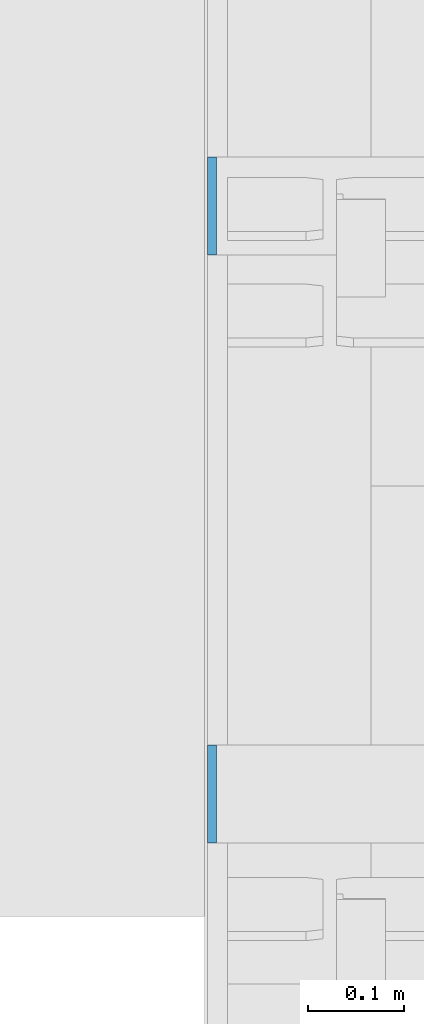
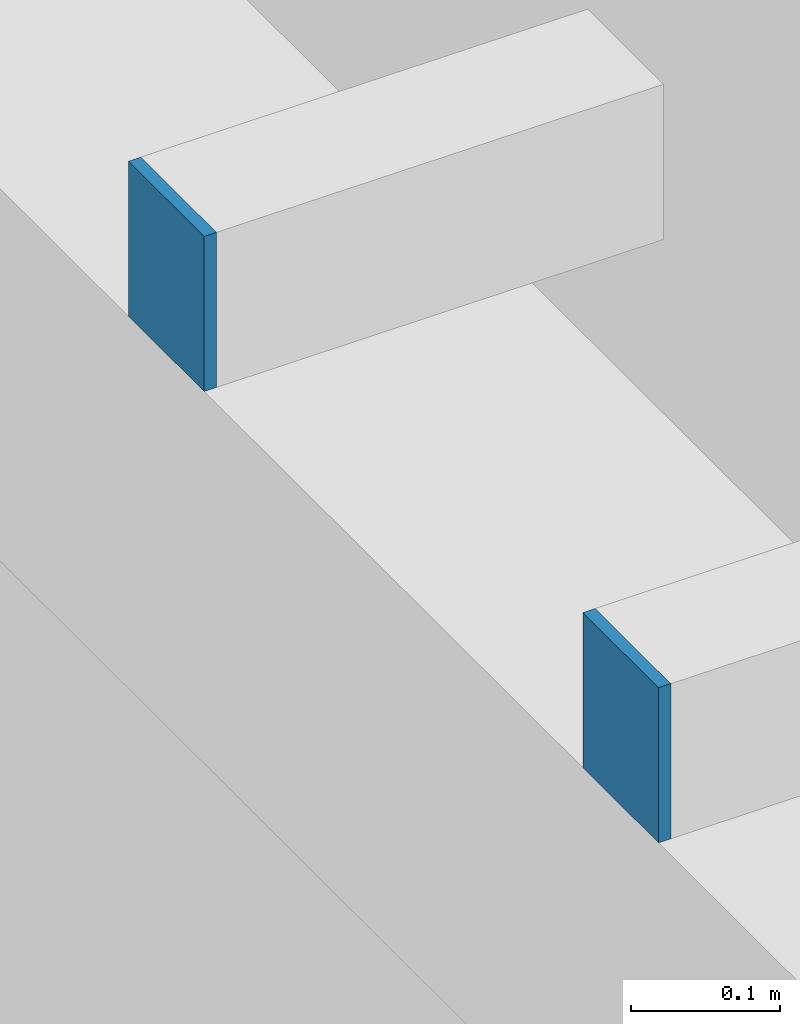
# One storey, part 461 of 1179: 2 columns, 2 elements without a shape of their own.
"""IFC2X3 building model written with IfcOpenShell, lengths in millimetres."""

from ifc_helpers import new_model, si_unit, frame, origin_with_axes, place, context, subcontext, project, spatial, faceted_brep, material, type_object, element, aggregate, save


model = new_model("IFC2X3")

# Units and contexts
model_context = context("Model", 3, precision=1e-05, world=origin_with_axes())
body_context = subcontext(model_context, "Body", "Model", "MODEL_VIEW")
ifc_project = project(units=[si_unit("LENGTHUNIT", "METRE", prefix="MILLI"), si_unit("AREAUNIT", "SQUARE_METRE"), si_unit("VOLUMEUNIT", "CUBIC_METRE"), si_unit("MASSUNIT", "GRAM", prefix="KILO"), si_unit("TIMEUNIT", "SECOND"), si_unit("PLANEANGLEUNIT", "RADIAN"), si_unit("SOLIDANGLEUNIT", "STERADIAN"), si_unit("THERMODYNAMICTEMPERATUREUNIT", "DEGREE_CELSIUS"), si_unit("LUMINOUSINTENSITYUNIT", "LUMEN")], contexts=[model_context])

# Site, building, storey
site_placement = place(None, origin_with_axes())
site = spatial("IfcSite", under=ifc_project, at=site_placement, CompositionType="ELEMENT")
building_placement = place(site_placement, origin_with_axes())
building = spatial("IfcBuilding", under=site, at=building_placement, Name="Undefined", CompositionType="ELEMENT")
storey_placement = place(building_placement, origin_with_axes())
storey = spatial("IfcBuildingStorey", under=building, at=storey_placement, Name="Undefined", CompositionType="ELEMENT", Elevation=0.0)

# Assembly, column
assembly_1_placement = place(storey_placement, origin_with_axes())
assembly_1 = element("IfcElementAssembly", 1, at=assembly_1_placement, inside=storey, Name="BEAM", AssemblyPlace="NOTDEFINED", PredefinedType="RIGID_FRAME")
ifc_material = material(Name="STEEL/A36")
column_type = type_object("IfcColumnType", PredefinedType="NOTDEFINED")
column_1_placement = place(assembly_1_placement, frame((24185.5625, 25577.8, 8013.69999998781), z_axis=(0.0, -1.0, 0.0), x_axis=(0.0, 0.0, 1.0)))
column_1 = element("IfcColumn", 2, at=column_1_placement, type_object=column_type, material=ifc_material, Name="PLATE", context=body_context, shape_type="Brep", body=[
    faceted_brep([(0.0, 4.76249999999982, -50.7999999999993), (0.0, 4.76249999999982, 50.7999999999993), (127.000000000371, 4.76249999928405, 50.8000000000002), (127.000000000371, 4.76249999928405, -50.8000000000002), (0.0, -4.76249999999982, 50.7999999999993), (127.0, -4.76250000000073, 50.7999999999993), (0.0, -4.76249999999982, -50.7999999999993), (127.0, -4.76250000000073, -50.7999999999993)], [[[0, 1, 2, 3]], [[1, 4, 5, 2]], [[4, 6, 7, 5]], [[6, 0, 3, 7]], [[5, 7, 3, 2]], [[6, 4, 1, 0]]]),
])
aggregate(assembly_1, [column_1])

assembly_2_placement = place(storey_placement, origin_with_axes())
assembly_2 = element("IfcElementAssembly", 3, at=assembly_2_placement, inside=storey, Name="BEAM", AssemblyPlace="NOTDEFINED", PredefinedType="RIGID_FRAME")
column_2_placement = place(assembly_2_placement, frame((24185.5625, 24968.2, 8013.69999998781), z_axis=(0.0, -1.0, 0.0), x_axis=(0.0, 0.0, 1.0)))
column_2 = element("IfcColumn", 4, at=column_2_placement, type_object=column_type, material=ifc_material, Name="PLATE", context=body_context, shape_type="Brep", body=[
    faceted_brep([(0.0, 4.76249999999982, -50.7999999999993), (0.0, 4.76249999999982, 50.7999999999993), (127.000000000371, 4.76249999928405, 50.8000000000002), (127.000000000371, 4.76249999928405, -50.8000000000002), (0.0, -4.76249999999982, 50.7999999999993), (127.0, -4.76250000000073, 50.7999999999993), (0.0, -4.76249999999982, -50.7999999999993), (127.0, -4.76250000000073, -50.7999999999993)], [[[0, 1, 2, 3]], [[1, 4, 5, 2]], [[4, 6, 7, 5]], [[6, 0, 3, 7]], [[5, 7, 3, 2]], [[6, 4, 1, 0]]]),
])
aggregate(assembly_2, [column_2])

save(model, "model.ifc")
